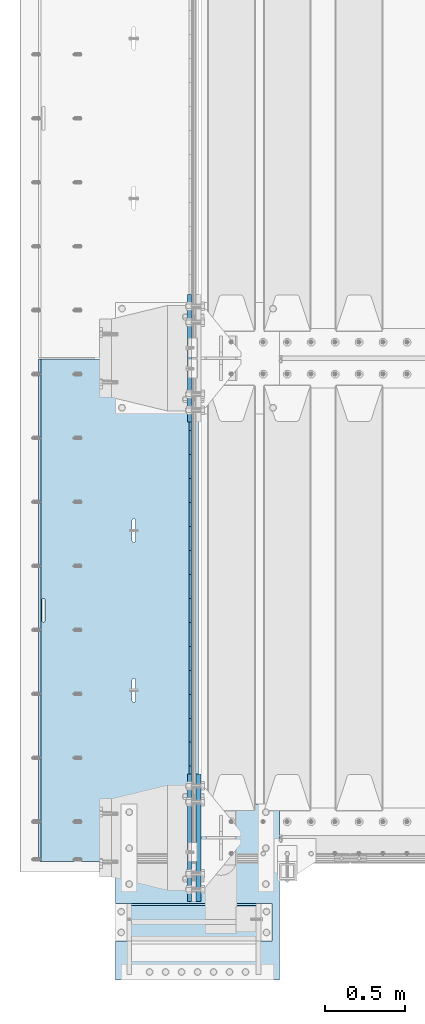
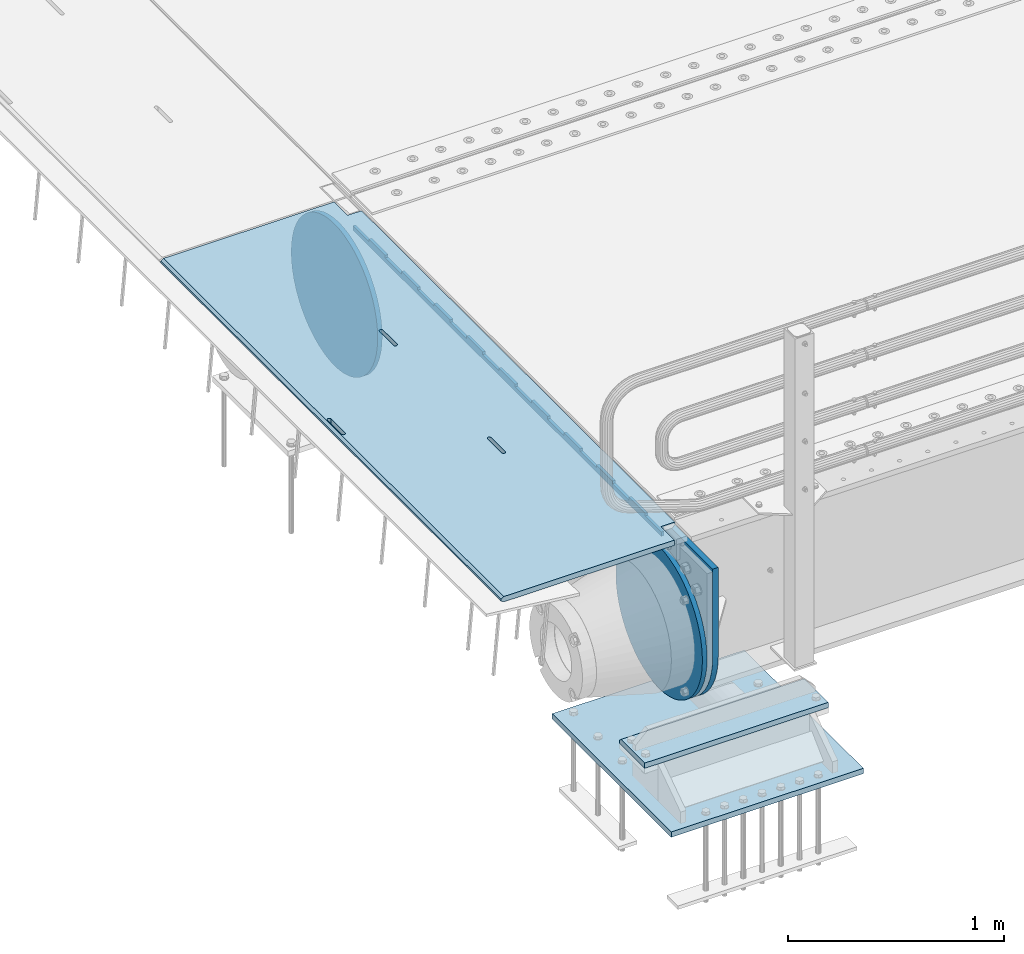
# One storey, part 168 of 219: 7 plates.
"""IFC2X3 building model written with IfcOpenShell, lengths in millimetres."""

from ifc_helpers import new_model, si_unit, frame, origin_with_axes, place, context, subcontext, project, spatial, faceted_brep, material, type_object, element, save


model = new_model("IFC2X3")

# Units and contexts
model_context = context("Model", 3, precision=1e-05, world=origin_with_axes())
body_context = subcontext(model_context, "Body", "Model", "MODEL_VIEW")
ifc_project = project(units=[si_unit("LENGTHUNIT", "METRE", prefix="MILLI"), si_unit("AREAUNIT", "SQUARE_METRE"), si_unit("VOLUMEUNIT", "CUBIC_METRE"), si_unit("MASSUNIT", "GRAM", prefix="KILO"), si_unit("TIMEUNIT", "SECOND"), si_unit("PLANEANGLEUNIT", "RADIAN"), si_unit("SOLIDANGLEUNIT", "STERADIAN"), si_unit("THERMODYNAMICTEMPERATUREUNIT", "DEGREE_CELSIUS"), si_unit("LUMINOUSINTENSITYUNIT", "LUMEN")], contexts=[model_context])

# Site, building, storey
site_placement = place(None, origin_with_axes())
site = spatial("IfcSite", under=ifc_project, at=site_placement, CompositionType="ELEMENT")
building_placement = place(site_placement, origin_with_axes())
building = spatial("IfcBuilding", under=site, at=building_placement, Name="Standard", CompositionType="ELEMENT")
storey_placement = place(building_placement, origin_with_axes())
storey = spatial("IfcBuildingStorey", under=building, at=storey_placement, Name="Undefined", CompositionType="ELEMENT", Elevation=0.0)

# Plates
ifc_material_1 = material(Name="STEEL/S355N")
plate_type_1 = type_object("IfcPlateType", PredefinedType="NOTDEFINED")
plate_1_placement = place(storey_placement, frame((-57.5000000000039, 26847.5000993725, -35.9858217365063), z_axis=(0.0, -0.999999999987744, -4.95099999993769e-06), x_axis=(0.0, 4.95100000930963e-06, -0.999999999987744)))
element("IfcPlate", 1, at=plate_1_placement, inside=storey, type_object=plate_type_1, material=ifc_material_1, context=body_context, shape_type="Brep", body=[
    faceted_brep([(0.0, -7.49999999999999, 0.0), (8.68993765834603e-12, -7.49999999999999, 150.000000000004), (8.68993765834603e-12, 7.5, 150.000000000004), (0.0, 7.5, 0.0), (-14.9999999999986, -7.49999999999999, 150.0), (-14.9999999999986, 7.5, 150.0), (-14.9999999999972, -7.49999999999999, 300.0), (-14.9999999999972, 7.5, 300.0), (1.55395696310734e-11, -7.49999999999999, 300.0), (1.55395696310734e-11, 7.5, 300.0), (1.87725390787818e-11, -7.49999999999999, 450.0), (1.87725390787818e-11, 7.5, 450.0), (-14.9999999999958, -7.49999999999999, 450.0), (-14.9999999999958, 7.5, 450.0), (-14.9999999999944, -7.49999999999999, 600.0), (-14.9999999999944, 7.5, 600.0), (2.74553713097703e-11, -7.49999999999999, 600.000000000004), (2.74553713097703e-11, 7.5, 600.000000000004), (3.24931193063094e-11, -7.49999999999999, 750.0), (3.24931193063094e-11, 7.5, 750.0), (-14.999999999993, -7.49999999999999, 750.0), (-14.999999999993, 7.5, 750.0), (-14.9999999999916, -7.49999999999999, 900.000000000004), (-14.9999999999916, 7.5, 900.000000000004), (4.11830569646554e-11, -7.49999999999999, 900.0), (4.11830569646554e-11, 7.5, 900.0), (4.62208049611945e-11, -7.49999999999999, 1050.0), (4.62208049611945e-11, 7.5, 1050.0), (-14.9999999999902, -7.49999999999999, 1050.0), (-14.9999999999902, 7.5, 1050.0), (-14.9999999999888, -7.49999999999999, 1200.0), (-14.9999999999888, 7.5, 1200.0), (5.30917532159947e-11, -7.49999999999999, 1200.0), (5.30917532159947e-11, 7.5, 1200.0), (5.99484906160797e-11, -7.49999999999999, 1350.0), (5.99484906160797e-11, 7.5, 1350.0), (-14.9999999999873, -7.49999999999999, 1350.0), (-14.9999999999873, 7.5, 1350.0), (-14.9999999999859, -7.49999999999999, 1500.0), (-14.9999999999859, 7.5, 1500.0), (6.49933440399764e-11, -7.49999999999999, 1500.0), (6.49933440399764e-11, 7.5, 1500.0), (7.36761762709648e-11, -7.49999999999999, 1650.0), (7.36761762709648e-11, 7.5, 1650.0), (-14.9999999999845, -7.49999999999999, 1650.0), (-14.9999999999845, 7.5, 1650.0), (-14.9999999999831, -7.49999999999999, 1800.0), (-14.9999999999831, 7.5, 1800.0), (7.6894934863958e-11, -7.49999999999999, 1800.0), (7.6894934863958e-11, 7.5, 1800.0), (8.37587776914006e-11, -7.49999999999999, 1950.0), (8.37587776914006e-11, 7.5, 1950.0), (-14.9999999999817, -7.49999999999999, 1950.0), (-14.9999999999817, 7.5, 1950.0), (-14.9999999999803, -7.49999999999999, 2100.0), (-14.9999999999803, 7.5, 2100.0), (9.06297259462008e-11, -7.49999999999999, 2100.0), (9.06297259462008e-11, 7.5, 2100.0), (9.56674739427399e-11, -7.49999999999999, 2250.0), (9.56674739427399e-11, 7.5, 2250.0), (-14.9999999999789, -7.49999999999999, 2250.0), (-14.9999999999789, 7.5, 2250.0), (-14.9999999999775, -7.49999999999999, 2400.0), (-14.9999999999775, 7.5, 2400.0), (1.04350306173728e-10, -7.49999999999999, 2400.0), (1.04350306173728e-10, 7.5, 2400.0), (1.09388054170267e-10, -7.49999999999999, 2550.0), (1.09388054170267e-10, 7.5, 2550.0), (-14.9999999999761, -7.49999999999999, 2550.0), (-14.9999999999761, 7.5, 2550.0), (-14.9999999999747, -7.49999999999999, 2700.0), (-14.9999999999747, 7.5, 2700.0), (1.14440013021522e-10, -7.49999999999999, 2700.0), (1.14440013021522e-10, 7.5, 2700.0), (1.23115739825153e-10, -7.49999999999999, 2850.0), (1.23115739825153e-10, 7.5, 2850.0), (25.0000000000267, -7.49999999999999, 2850.0), (25.0000000000267, 7.5, 2850.0), (25.0, -7.49999999999999, 0.0), (25.0, 7.5, 0.0)], [[[0, 1, 2, 3]], [[1, 4, 5, 2]], [[4, 6, 7, 5]], [[6, 8, 9, 7]], [[8, 10, 11, 9]], [[10, 12, 13, 11]], [[12, 14, 15, 13]], [[14, 16, 17, 15]], [[16, 18, 19, 17]], [[18, 20, 21, 19]], [[20, 22, 23, 21]], [[22, 24, 25, 23]], [[24, 26, 27, 25]], [[26, 28, 29, 27]], [[28, 30, 31, 29]], [[30, 32, 33, 31]], [[32, 34, 35, 33]], [[34, 36, 37, 35]], [[36, 38, 39, 37]], [[38, 40, 41, 39]], [[40, 42, 43, 41]], [[42, 44, 45, 43]], [[44, 46, 47, 45]], [[46, 48, 49, 47]], [[48, 50, 51, 49]], [[50, 52, 53, 51]], [[52, 54, 55, 53]], [[54, 56, 57, 55]], [[56, 58, 59, 57]], [[58, 60, 61, 59]], [[60, 62, 63, 61]], [[62, 64, 65, 63]], [[64, 66, 67, 65]], [[66, 68, 69, 67]], [[68, 70, 71, 69]], [[70, 72, 73, 71]], [[72, 74, 75, 73]], [[74, 76, 77, 75]], [[76, 78, 79, 77]], [[78, 0, 3, 79]], [[5, 7, 9, 11, 13, 15, 17, 19, 21, 23, 25, 27, 29, 31, 33, 35, 37, 39, 41, 43, 45, 47, 49, 51, 53, 55, 57, 59, 61, 63, 65, 67, 69, 71, 73, 75, 77, 79, 3, 2]], [[78, 76, 74, 72, 70, 68, 66, 64, 62, 60, 58, 56, 54, 52, 50, 48, 46, 44, 42, 40, 38, 36, 34, 32, 30, 28, 26, 24, 22, 20, 18, 16, 14, 12, 10, 8, 6, 4, 1, 0]]]),
])
plate_type_2 = type_object("IfcPlateType", PredefinedType="NOTDEFINED")
plate_2_placement = place(storey_placement, frame((-5.00375457095084, 26994.9999261293, -0.984429074950506), z_axis=(0.0, -0.999999999987744, -4.95099999993769e-06), x_axis=(-0.999999999879068, -1.00000022172504e-09, -1.55519999981193e-05)))
element("IfcPlate", 2, at=plate_2_placement, inside=storey, type_object=plate_type_2, material=ifc_material_1, context=body_context, shape_type="Brep", body=[
    faceted_brep([(14.9998601691701, 15.0, 125.000024820867), (-0.000294611402126499, -0.000806902977099622, 124.999936248674), (-0.0019194158154896, 0.000806844435372156, 3020.00000492308), (14.9966216875132, 15.0, 3020.00007976656), (999.996459960937, 4.99999999999999, 3.63797880709171e-12), (984.996459960937, 15.0, 3.63797880709171e-12), (984.996459718778, 15.0, 3145.0), (999.996459718778, 4.99999999999999, 3145.0), (984.996459961366, -15.0, 0.0), (999.996459960937, -5.0, 3.63797880709171e-12), (999.996459718778, -5.0, 3145.0), (984.996459719206, -15.0, 3145.0), (74.999782061445, -15.0, 0.0), (74.9996421865538, -15.0000000127077, 124.999930084141), (75.0001087165527, 15.0, 125.00007975414), (75.0002485914438, 15.0, 0.0), (-0.000449375328763324, -14.9999999951864, 124.999861417786), (960.486056642603, -14.9999999941054, 1504.40983005424), (960.486056642603, 15.0, 1504.40983005424), (959.996621805317, 15.0, 1507.49999999799), (959.996621805317, -14.9999999941178, 1507.49999999799), (961.90645186202, -14.9999999940729, 1501.62214747507), (961.906451862021, 15.0, 1501.62214747506), (964.118769283016, -14.9999999940233, 1499.40983005424), (964.118769283016, 15.0, 1499.40983005424), (966.9064518623, -14.9999999939616, 1497.98943483504), (966.906451862301, 15.0, 1497.98943483504), (969.996621806087, -14.9999999938938, 1497.49999999799), (969.996621806088, 15.0, 1497.49999999799), (973.086791749683, -14.9999999938266, 1497.98943483504), (973.086791749683, 15.0, 1497.98943483504), (975.874474328748, -14.9999999937664, 1499.40983005424), (975.874474328748, 15.0, 1499.40983005424), (978.086791749402, -14.9999999937193, 1501.62214747506), (978.086791749402, 15.0, 1501.62214747506), (979.50718696839, -14.9999999936897, 1504.40983005424), (979.50718696839, 15.0, 1504.40983005424), (979.996621805202, -14.9999999936807, 1507.49999999798), (979.996621805202, 15.0, 1507.49999999798), (979.996621795288, -14.9999999937513, 1637.49999999798), (979.996621795288, 15.0, 1637.49999999798), (979.507186958004, -14.9999999937636, 1640.59016994173), (979.507186958004, 15.0, 1640.59016994173), (978.086791738588, -14.9999999937962, 1643.37785252092), (978.086791738588, 15.0, 1643.37785252092), (975.874474317592, -14.9999999938457, 1645.59016994174), (975.874474317592, 15.0, 1645.59016994174), (973.086791738306, -14.9999999939074, 1647.01056516094), (973.086791738306, 15.0, 1647.01056516094), (969.996621794518, -14.9999999939752, 1647.499999998), (969.996621794518, 15.0, 1647.49999999799), (966.906451850814, -14.9999999940425, 1647.01056516094), (966.906451850814, 15.0, 1647.01056516094), (964.118769271748, -14.9999999941026, 1645.59016994174), (964.118769271748, 15.0, 1645.59016994174), (961.906451851094, -14.9999999941498, 1643.37785252092), (961.906451851094, 15.0, 1643.37785252092), (960.486056632107, -14.9999999941793, 1640.59016994174), (960.486056632107, 15.0, 1640.59016994174), (959.996621795297, -14.9999999941883, 1637.49999999799), (959.996621795297, 15.0, 1637.49999999799), (395.486056681091, -15.0000000061812, 1004.40983005449), (395.486056681091, 15.0, 1004.40983005448), (394.996621843805, 15.0, 1007.49999999824), (394.996621843805, -15.0000000061936, 1007.49999999824), (396.906451900508, -15.0000000061487, 1001.62214747531), (396.906451900508, 15.0, 1001.62214747531), (399.118769321504, -15.0000000060991, 999.409830054483), (399.118769321504, 15.0, 999.409830054483), (401.906451900788, -15.0000000060374, 997.989434835286), (401.906451900788, 15.0, 997.989434835283), (404.996621844575, -15.0000000059696, 997.499999998232), (404.996621844575, 15.0, 997.499999998228), (408.086791788171, -15.0000000059024, 997.989434835283), (408.086791788171, 15.0, 997.989434835283), (410.874474367236, -15.0000000058422, 999.409830054483), (410.874474367236, 15.0, 999.409830054483), (413.08679178789, -15.0000000057951, 1001.62214747531), (413.08679178789, 15.0, 1001.6221474753), (414.507187006878, -15.0000000057655, 1004.40983005448), (414.507187006878, 15.0, 1004.40983005448), (414.99662184369, -15.0000000057565, 1007.49999999823), (414.99662184369, 15.0, 1007.49999999822), (414.996621833776, -15.0000000058271, 1137.49999999823), (414.996621833776, 15.0, 1137.49999999822), (414.507186996492, -15.0000000058395, 1140.59016994198), (414.507186996492, 15.0, 1140.59016994198), (413.086791777076, -15.000000005872, 1143.37785252116), (413.086791777076, 15.0, 1143.37785252115), (410.87447435608, -15.0000000059215, 1145.59016994198), (410.87447435608, 15.0, 1145.59016994198), (408.086791776794, -15.0000000059832, 1147.01056516119), (408.086791776794, 15.0, 1147.01056516119), (404.996621833006, -15.000000006051, 1147.49999999823), (404.996621833006, 15.0, 1147.49999999823), (401.906451889302, -15.0000000061183, 1147.01056516119), (401.906451889302, 15.0, 1147.01056516118), (399.118769310236, -15.0000000061784, 1145.59016994198), (399.118769310236, 15.0, 1145.59016994198), (396.906451889582, -15.0000000062256, 1143.37785252116), (396.906451889582, 15.0, 1143.37785252116), (395.486056670595, -15.0000000062551, 1140.59016994198), (395.486056670595, 15.0, 1140.59016994198), (394.996621833785, -15.0000000062641, 1137.49999999824), (394.996621833785, 15.0, 1137.49999999824), (74.9967306508983, 15.0, 3145.0), (74.9962640908995, -15.0, 3145.0), (74.9968705257886, 15.0, 3020.00007982416), (74.9964039657899, -15.0, 3019.99993015416), (-0.000460362174934836, -15.00000004538, 3019.99993008595), (395.486056593611, -15.0000000067978, 2140.5901699415), (396.906451812598, -15.0000000067683, 2143.37785252068), (399.118769233252, -15.0000000067211, 2145.5901699415), (401.906451812318, -15.000000006661, 2147.01056516071), (404.996621756022, -15.0000000065937, 2147.49999999775), (408.08679169981, -15.0000000065259, 2147.01056516071), (410.874474279096, -15.0000000064642, 2145.5901699415), (413.086791700092, -15.0000000064147, 2143.37785252068), (414.507186919508, -15.0000000063821, 2140.5901699415), (414.996621756792, -15.0000000063698, 2137.49999999775), (414.996621766706, -15.0000000062992, 2007.49999999775), (414.507186929894, -15.0000000063082, 2004.409830054), (413.086791710906, -15.0000000063378, 2001.62214747483), (410.874474290252, -15.0000000063849, 1999.409830054), (408.086791711187, -15.0000000064451, 1997.9894348348), (404.996621767592, -15.0000000065123, 1997.49999999776), (401.906451823804, -15.0000000065801, 1997.98943483481), (399.11876924452, -15.0000000066418, 1999.409830054), (396.906451823524, -15.0000000066914, 2001.62214747483), (395.486056604107, -15.0000000067239, 2004.409830054), (394.996621766821, -15.0000000067363, 2007.49999999776), (394.996621756801, -15.0000000068068, 2137.49999999776), (396.906451823524, 15.0, 2001.62214747483), (395.486056604107, 15.0, 2004.409830054), (399.11876924452, 15.0, 1999.409830054), (401.906451823804, 15.0, 1997.9894348348), (404.996621767592, 15.0, 1997.49999999775), (408.086791711187, 15.0, 1997.9894348348), (410.874474290252, 15.0, 1999.409830054), (413.086791710906, 15.0, 2001.62214747482), (414.507186929894, 15.0, 2004.409830054), (414.996621766706, 15.0, 2007.49999999774), (414.996621756792, 15.0, 2137.49999999774), (414.507186919508, 15.0, 2140.5901699415), (413.086791700092, 15.0, 2143.37785252067), (410.874474279096, 15.0, 2145.5901699415), (408.08679169981, 15.0, 2147.01056516071), (404.996621756022, 15.0, 2147.49999999775), (401.906451812318, 15.0, 2147.0105651607), (399.118769233252, 15.0, 2145.5901699415), (396.906451812598, 15.0, 2143.37785252068), (395.486056593611, 15.0, 2140.5901699415), (394.996621756801, 15.0, 2137.49999999776), (394.996621766821, 15.0, 2007.49999999776)], [[[0, 1, 2, 3]], [[4, 5, 6, 7]], [[8, 9, 10, 11]], [[12, 13, 14, 15]], [[14, 13, 16, 1, 0]], [[17, 18, 19, 20]], [[21, 22, 18, 17]], [[23, 24, 22, 21]], [[25, 26, 24, 23]], [[27, 28, 26, 25]], [[29, 30, 28, 27]], [[31, 32, 30, 29]], [[33, 34, 32, 31]], [[35, 36, 34, 33]], [[37, 38, 36, 35]], [[39, 40, 38, 37]], [[41, 42, 40, 39]], [[43, 44, 42, 41]], [[45, 46, 44, 43]], [[47, 48, 46, 45]], [[49, 50, 48, 47]], [[51, 52, 50, 49]], [[53, 54, 52, 51]], [[55, 56, 54, 53]], [[57, 58, 56, 55]], [[59, 60, 58, 57]], [[20, 19, 60, 59]], [[61, 62, 63, 64]], [[65, 66, 62, 61]], [[67, 68, 66, 65]], [[69, 70, 68, 67]], [[71, 72, 70, 69]], [[73, 74, 72, 71]], [[75, 76, 74, 73]], [[77, 78, 76, 75]], [[79, 80, 78, 77]], [[81, 82, 80, 79]], [[83, 84, 82, 81]], [[85, 86, 84, 83]], [[87, 88, 86, 85]], [[89, 90, 88, 87]], [[91, 92, 90, 89]], [[93, 94, 92, 91]], [[95, 96, 94, 93]], [[97, 98, 96, 95]], [[99, 100, 98, 97]], [[101, 102, 100, 99]], [[103, 104, 102, 101]], [[64, 63, 104, 103]], [[9, 8, 12, 15, 5, 4]], [[10, 9, 4, 7]], [[105, 106, 11, 10, 7, 6]], [[106, 105, 107, 108]], [[109, 108, 107, 3, 2]], [[106, 108, 109, 16, 13, 12, 8, 11], [101, 99, 97, 95, 93, 91, 89, 87, 85, 83, 81, 79, 77, 75, 73, 71, 69, 67, 65, 61, 64, 103], [57, 55, 53, 51, 49, 47, 45, 43, 41, 39, 37, 35, 33, 31, 29, 27, 25, 23, 21, 17, 20, 59], [110, 111, 112, 113, 114, 115, 116, 117, 118, 119, 120, 121, 122, 123, 124, 125, 126, 127, 128, 129, 130, 131]], [[128, 132, 133, 129]], [[127, 134, 132, 128]], [[126, 135, 134, 127]], [[125, 136, 135, 126]], [[124, 137, 136, 125]], [[123, 138, 137, 124]], [[122, 139, 138, 123]], [[121, 140, 139, 122]], [[120, 141, 140, 121]], [[119, 142, 141, 120]], [[118, 143, 142, 119]], [[117, 144, 143, 118]], [[116, 145, 144, 117]], [[115, 146, 145, 116]], [[114, 147, 146, 115]], [[113, 148, 147, 114]], [[112, 149, 148, 113]], [[111, 150, 149, 112]], [[110, 151, 150, 111]], [[131, 152, 151, 110]], [[130, 153, 152, 131]], [[129, 133, 153, 130]], [[107, 105, 6, 5, 15, 14, 0, 3], [132, 134, 135, 136, 137, 138, 139, 140, 141, 142, 143, 144, 145, 146, 147, 148, 149, 150, 151, 152, 153, 133], [22, 24, 26, 28, 30, 32, 34, 36, 38, 40, 42, 44, 46, 48, 50, 52, 54, 56, 58, 60, 19, 18], [66, 68, 70, 72, 74, 76, 78, 80, 82, 84, 86, 88, 90, 92, 94, 96, 98, 100, 102, 104, 63, 62]], [[16, 109, 2, 1]]]),
])
ifc_material_2 = material()
plate_type_3 = type_object("IfcPlateType", PredefinedType="NOTDEFINED")
plate_3_placement = place(storey_placement, frame((455.000000000013, 23355.0, -803.000000000004), z_axis=(0.0, 1.0, 0.0), x_axis=(-1.0, 0.0, 0.0)))
element("IfcPlate", 3, at=plate_3_placement, inside=storey, type_object=plate_type_3, material=ifc_material_2, context=body_context, shape_type="Brep", body=[
    faceted_brep([(979.0, 0.0, 235.0), (979.0, 15.0, 220.0), (0.0, 15.0, 220.0), (0.0, 0.0, 235.0), (0.0, 15.0, 0.0), (0.0, -15.0, 0.0), (0.0, -15.0, 235.0), (979.0, -15.0, 235.0), (979.0, -15.0, 0.0), (979.0, 15.0, 0.0)], [[[0, 1, 2, 3]], [[4, 5, 6, 3, 2]], [[6, 7, 0, 3]], [[7, 8, 9, 1, 0]], [[8, 5, 4, 9]], [[9, 4, 2, 1]], [[8, 7, 6, 5]]]),
])
plate_type_4 = type_object("IfcPlateType", PredefinedType="NOTDEFINED")
plate_4_placement = place(storey_placement, frame((-523.999999999987, 23110.0, -1043.0), z_axis=(1.0, 0.0, 0.0), x_axis=(0.0, 1.0, 0.0)))
element("IfcPlate", 4, at=plate_4_placement, inside=storey, type_object=plate_type_4, material=ifc_material_2, context=body_context, shape_type="Brep", body=[
    faceted_brep([(0.0, -15.0, 0.0), (3.03448287013453e-05, -15.0, 1025.0), (3.03448287013453e-05, 15.0, 1025.0), (0.0, 15.0, 0.0), (1100.0, -15.0, 1025.0), (1100.0, 15.0, 1025.0), (1100.0, -15.0, -1.9554136088118e-11), (1100.0, 15.0, -1.9554136088118e-11)], [[[0, 1, 2, 3]], [[1, 4, 5, 2]], [[4, 6, 7, 5]], [[6, 0, 3, 7]], [[5, 7, 3, 2]], [[6, 4, 1, 0]]]),
])
plate_type_5 = type_object("IfcPlateType", PredefinedType="NOTDEFINED")
plate_5_placement = place(storey_placement, frame((-62.5000000000001, 27400.0, -114.999999999998), z_axis=(0.0, 0.0, -1.0), x_axis=(0.0, -1.0, 0.0)))
element("IfcPlate", 5, at=plate_5_placement, inside=storey, type_object=plate_type_5, material=ifc_material_1, context=body_context, shape_type="Brep", body=[
    faceted_brep([(0.0, -12.5, 400.0), (2.91645036198315, -12.5, 448.214672101512), (2.91645036198315, 12.5, 448.214672101512), (0.0, 12.5, 400.0), (11.6232730309421, -12.5, 495.72626571426), (11.6232730309421, 12.5, 495.72626571426), (25.9935029273329, -12.5, 541.8419548161), (25.9935029273329, 12.5, 541.8419548161), (45.8175897403271, -12.5, 585.889268816449), (45.8175897403271, 12.5, 585.889268816449), (70.8064536442325, -12.5, 627.225898691271), (70.8064536442325, 12.5, 627.225898691271), (100.595700733313, -12.5, 665.249063294999), (100.595700733313, 12.5, 665.249063294999), (134.750936705474, -12.5, 699.404299267018), (134.750936705474, 12.5, 699.404299267018), (172.774101309333, -12.5, 729.193546355957), (172.774101309333, 12.5, 729.193546355957), (214.110731184279, -12.5, 754.182410259709), (214.110731184279, 12.5, 754.182410259709), (258.15804518474, -12.5, 774.006497072558), (258.15804518474, 12.5, 774.006497072558), (304.273734286682, -12.5, 788.376726968803), (304.273734286682, 12.5, 788.376726968803), (351.785327899517, -12.5, 797.08354963762), (351.785327899517, 12.5, 797.08354963762), (400.0, -12.5, 800.0), (400.0, 12.5, 800.0), (448.21467210335, -12.5, 797.083549637642), (448.21467210335, 12.5, 797.083549637642), (495.726265715995, -12.5, 788.37672696916), (495.726265715995, 12.5, 788.37672696916), (541.841954817748, -12.5, 774.006497073235), (541.841954817748, 12.5, 774.006497073235), (585.889268818006, -12.5, 754.182410260695), (585.889268818006, 12.5, 754.182410260695), (627.225898692734, -12.5, 729.193546357212), (627.225898692734, 12.5, 729.193546357212), (665.249063296356, -12.5, 699.404299268539), (665.249063296356, 12.5, 699.404299268539), (699.404299268259, -12.5, 665.24906329676), (699.404299268259, 12.5, 665.24906329676), (729.193546357063, -12.5, 627.22589869325), (729.193546357063, 12.5, 627.22589869325), (754.18241026067, -12.5, 585.889268818639), (754.18241026067, 12.5, 585.889268818639), (774.006497073347, -12.5, 541.841954818479), (774.006497073347, 12.5, 541.841954818479), (788.376726969396, -12.5, 495.726265716821), (788.376726969396, 12.5, 495.726265716821), (797.083549638002, -12.5, 448.214672104252), (797.083549638002, 12.5, 448.214672104252), (800.0, -12.5, 400.0), (800.0, 12.5, 400.0), (797.083549639287, -12.5, 351.785327898364), (797.083549639287, 12.5, 351.785327898364), (788.376726970528, -12.5, 304.273734285453), (788.376726970528, 12.5, 304.273734285453), (774.006497074311, -12.5, 258.158045183416), (774.006497074311, 12.5, 258.158045183416), (754.182410261463, -12.5, 214.110731182853), (754.182410261463, 12.5, 214.110731182853), (729.193546357659, -12.5, 172.774101307812), (729.193546357659, 12.5, 172.774101307812), (699.404299268663, -12.5, 134.750936703855), (699.404299268663, 12.5, 134.750936703855), (665.24906329656, -12.5, 100.595700731628), (665.24906329656, 12.5, 100.595700731628), (627.225898692719, -12.5, 70.8064536425045), (627.225898692719, 12.5, 70.8064536425045), (585.889268817788, -12.5, 45.8175897385809), (585.889268817788, 12.5, 45.8175897385809), (541.841954817326, -12.5, 25.9935029256012), (541.841954817326, 12.5, 25.9935029256012), (495.726265715377, -12.5, 11.6232730292504), (495.726265715377, 12.5, 11.6232730292504), (448.214672102542, -12.5, 2.91645036037517), (448.214672102542, 12.5, 2.91645036037517), (400.0, -12.5, -5.6843418860808e-14), (400.0, 12.5, -5.6843418860808e-14), (351.785327896665, -12.5, 2.91645036236514), (351.785327896665, 12.5, 2.91645036236514), (304.273734284012, -12.5, 11.6232730308511), (304.273734284012, 12.5, 11.6232730308511), (258.158045182267, -12.5, 25.9935029267763), (258.158045182267, 12.5, 25.9935029267763), (214.110731182009, -12.5, 45.8175897393157), (214.110731182009, 12.5, 45.8175897393157), (172.774101307281, -12.5, 70.8064536427992), (172.774101307281, 12.5, 70.8064536427992), (134.750936703655, -12.5, 100.595700731472), (134.750936703655, 12.5, 100.595700731472), (100.595700731748, -12.5, 134.750936703247), (100.595700731748, 12.5, 134.750936703247), (70.8064536429447, -12.5, 172.774101306761), (70.8064536429447, 12.5, 172.774101306761), (45.8175897393376, -12.5, 214.110731181379), (45.8175897393376, 12.5, 214.110731181379), (25.9935029266635, -12.5, 258.158045181532), (25.9935029266635, 12.5, 258.158045181532), (11.6232730306074, -12.5, 304.273734283186), (11.6232730306074, 12.5, 304.273734283186), (2.9164503619977, -12.5, 351.785327895759), (2.9164503619977, 12.5, 351.785327895759)], [[[0, 1, 2, 3]], [[1, 4, 5, 2]], [[4, 6, 7, 5]], [[6, 8, 9, 7]], [[8, 10, 11, 9]], [[10, 12, 13, 11]], [[12, 14, 15, 13]], [[14, 16, 17, 15]], [[16, 18, 19, 17]], [[18, 20, 21, 19]], [[20, 22, 23, 21]], [[22, 24, 25, 23]], [[24, 26, 27, 25]], [[26, 28, 29, 27]], [[28, 30, 31, 29]], [[30, 32, 33, 31]], [[32, 34, 35, 33]], [[34, 36, 37, 35]], [[36, 38, 39, 37]], [[38, 40, 41, 39]], [[40, 42, 43, 41]], [[42, 44, 45, 43]], [[44, 46, 47, 45]], [[46, 48, 49, 47]], [[48, 50, 51, 49]], [[50, 52, 53, 51]], [[52, 54, 55, 53]], [[54, 56, 57, 55]], [[56, 58, 59, 57]], [[58, 60, 61, 59]], [[60, 62, 63, 61]], [[62, 64, 65, 63]], [[64, 66, 67, 65]], [[66, 68, 69, 67]], [[68, 70, 71, 69]], [[70, 72, 73, 71]], [[72, 74, 75, 73]], [[74, 76, 77, 75]], [[76, 78, 79, 77]], [[78, 80, 81, 79]], [[80, 82, 83, 81]], [[82, 84, 85, 83]], [[84, 86, 87, 85]], [[86, 88, 89, 87]], [[88, 90, 91, 89]], [[90, 92, 93, 91]], [[92, 94, 95, 93]], [[94, 96, 97, 95]], [[96, 98, 99, 97]], [[98, 100, 101, 99]], [[100, 102, 103, 101]], [[102, 0, 3, 103]], [[5, 7, 9, 11, 13, 15, 17, 19, 21, 23, 25, 27, 29, 31, 33, 35, 37, 39, 41, 43, 45, 47, 49, 51, 53, 55, 57, 59, 61, 63, 65, 67, 69, 71, 73, 75, 77, 79, 81, 83, 85, 87, 89, 91, 93, 95, 97, 99, 101, 103, 3, 2]], [[102, 100, 98, 96, 94, 92, 90, 88, 86, 84, 82, 80, 78, 76, 74, 72, 70, 68, 66, 64, 62, 60, 58, 56, 54, 52, 50, 48, 46, 44, 42, 40, 38, 36, 34, 32, 30, 28, 26, 24, 22, 20, 18, 16, 14, 12, 10, 8, 6, 4, 1, 0]]]),
])
plate_6_placement = place(storey_placement, frame((-62.5000000000001, 24400.0, -114.999999999998), z_axis=(0.0, 0.0, -1.0), x_axis=(0.0, -1.0, 0.0)))
element("IfcPlate", 6, at=plate_6_placement, inside=storey, type_object=plate_type_5, material=ifc_material_1, context=body_context, shape_type="Brep", body=[
    faceted_brep([(0.0, -12.5, 400.0), (2.91645036198315, -12.5, 448.214672101512), (2.91645036198315, 12.5, 448.214672101512), (0.0, 12.5, 400.0), (11.6232730309421, -12.5, 495.72626571426), (11.6232730309421, 12.5, 495.72626571426), (25.9935029273329, -12.5, 541.8419548161), (25.9935029273329, 12.5, 541.8419548161), (45.8175897403271, -12.5, 585.889268816449), (45.8175897403271, 12.5, 585.889268816449), (70.8064536442325, -12.5, 627.225898691271), (70.8064536442325, 12.5, 627.225898691271), (100.595700733313, -12.5, 665.249063294999), (100.595700733313, 12.5, 665.249063294999), (134.750936705474, -12.5, 699.404299267018), (134.750936705474, 12.5, 699.404299267018), (172.774101309333, -12.5, 729.193546355957), (172.774101309333, 12.5, 729.193546355957), (214.110731184279, -12.5, 754.182410259709), (214.110731184279, 12.5, 754.182410259709), (258.15804518474, -12.5, 774.006497072558), (258.15804518474, 12.5, 774.006497072558), (304.273734286682, -12.5, 788.376726968803), (304.273734286682, 12.5, 788.376726968803), (351.785327899517, -12.5, 797.08354963762), (351.785327899517, 12.5, 797.08354963762), (400.0, -12.5, 800.0), (400.0, 12.5, 800.0), (448.21467210335, -12.5, 797.083549637642), (448.21467210335, 12.5, 797.083549637642), (495.726265715995, -12.5, 788.37672696916), (495.726265715995, 12.5, 788.37672696916), (541.841954817748, -12.5, 774.006497073235), (541.841954817748, 12.5, 774.006497073235), (585.889268818006, -12.5, 754.182410260695), (585.889268818006, 12.5, 754.182410260695), (627.225898692734, -12.5, 729.193546357212), (627.225898692734, 12.5, 729.193546357212), (665.249063296356, -12.5, 699.404299268539), (665.249063296356, 12.5, 699.404299268539), (699.404299268259, -12.5, 665.24906329676), (699.404299268259, 12.5, 665.24906329676), (729.193546357063, -12.5, 627.22589869325), (729.193546357063, 12.5, 627.22589869325), (754.18241026067, -12.5, 585.889268818639), (754.18241026067, 12.5, 585.889268818639), (774.006497073347, -12.5, 541.841954818479), (774.006497073347, 12.5, 541.841954818479), (788.376726969396, -12.5, 495.726265716821), (788.376726969396, 12.5, 495.726265716821), (797.083549638002, -12.5, 448.214672104252), (797.083549638002, 12.5, 448.214672104252), (800.0, -12.5, 400.0), (800.0, 12.5, 400.0), (797.083549639287, -12.5, 351.785327898364), (797.083549639287, 12.5, 351.785327898364), (788.376726970528, -12.5, 304.273734285453), (788.376726970528, 12.5, 304.273734285453), (774.006497074311, -12.5, 258.158045183416), (774.006497074311, 12.5, 258.158045183416), (754.182410261463, -12.5, 214.110731182853), (754.182410261463, 12.5, 214.110731182853), (729.193546357659, -12.5, 172.774101307812), (729.193546357659, 12.5, 172.774101307812), (699.404299268663, -12.5, 134.750936703855), (699.404299268663, 12.5, 134.750936703855), (665.24906329656, -12.5, 100.595700731628), (665.24906329656, 12.5, 100.595700731628), (627.225898692719, -12.5, 70.8064536425045), (627.225898692719, 12.5, 70.8064536425045), (585.889268817788, -12.5, 45.8175897385809), (585.889268817788, 12.5, 45.8175897385809), (541.841954817326, -12.5, 25.9935029256012), (541.841954817326, 12.5, 25.9935029256012), (495.726265715377, -12.5, 11.6232730292504), (495.726265715377, 12.5, 11.6232730292504), (448.214672102542, -12.5, 2.91645036037517), (448.214672102542, 12.5, 2.91645036037517), (400.0, -12.5, -5.6843418860808e-14), (400.0, 12.5, -5.6843418860808e-14), (351.785327896665, -12.5, 2.91645036236514), (351.785327896665, 12.5, 2.91645036236514), (304.273734284012, -12.5, 11.6232730308511), (304.273734284012, 12.5, 11.6232730308511), (258.158045182267, -12.5, 25.9935029267763), (258.158045182267, 12.5, 25.9935029267763), (214.110731182009, -12.5, 45.8175897393157), (214.110731182009, 12.5, 45.8175897393157), (172.774101307281, -12.5, 70.8064536427992), (172.774101307281, 12.5, 70.8064536427992), (134.750936703655, -12.5, 100.595700731472), (134.750936703655, 12.5, 100.595700731472), (100.595700731748, -12.5, 134.750936703247), (100.595700731748, 12.5, 134.750936703247), (70.8064536429447, -12.5, 172.774101306761), (70.8064536429447, 12.5, 172.774101306761), (45.8175897393376, -12.5, 214.110731181379), (45.8175897393376, 12.5, 214.110731181379), (25.9935029266635, -12.5, 258.158045181532), (25.9935029266635, 12.5, 258.158045181532), (11.6232730306074, -12.5, 304.273734283186), (11.6232730306074, 12.5, 304.273734283186), (2.9164503619977, -12.5, 351.785327895759), (2.9164503619977, 12.5, 351.785327895759)], [[[0, 1, 2, 3]], [[1, 4, 5, 2]], [[4, 6, 7, 5]], [[6, 8, 9, 7]], [[8, 10, 11, 9]], [[10, 12, 13, 11]], [[12, 14, 15, 13]], [[14, 16, 17, 15]], [[16, 18, 19, 17]], [[18, 20, 21, 19]], [[20, 22, 23, 21]], [[22, 24, 25, 23]], [[24, 26, 27, 25]], [[26, 28, 29, 27]], [[28, 30, 31, 29]], [[30, 32, 33, 31]], [[32, 34, 35, 33]], [[34, 36, 37, 35]], [[36, 38, 39, 37]], [[38, 40, 41, 39]], [[40, 42, 43, 41]], [[42, 44, 45, 43]], [[44, 46, 47, 45]], [[46, 48, 49, 47]], [[48, 50, 51, 49]], [[50, 52, 53, 51]], [[52, 54, 55, 53]], [[54, 56, 57, 55]], [[56, 58, 59, 57]], [[58, 60, 61, 59]], [[60, 62, 63, 61]], [[62, 64, 65, 63]], [[64, 66, 67, 65]], [[66, 68, 69, 67]], [[68, 70, 71, 69]], [[70, 72, 73, 71]], [[72, 74, 75, 73]], [[74, 76, 77, 75]], [[76, 78, 79, 77]], [[78, 80, 81, 79]], [[80, 82, 83, 81]], [[82, 84, 85, 83]], [[84, 86, 87, 85]], [[86, 88, 89, 87]], [[88, 90, 91, 89]], [[90, 92, 93, 91]], [[92, 94, 95, 93]], [[94, 96, 97, 95]], [[96, 98, 99, 97]], [[98, 100, 101, 99]], [[100, 102, 103, 101]], [[102, 0, 3, 103]], [[5, 7, 9, 11, 13, 15, 17, 19, 21, 23, 25, 27, 29, 31, 33, 35, 37, 39, 41, 43, 45, 47, 49, 51, 53, 55, 57, 59, 61, 63, 65, 67, 69, 71, 73, 75, 77, 79, 81, 83, 85, 87, 89, 91, 93, 95, 97, 99, 101, 103, 3, 2]], [[102, 100, 98, 96, 94, 92, 90, 88, 86, 84, 82, 80, 78, 76, 74, 72, 70, 68, 66, 64, 62, 60, 58, 56, 54, 52, 50, 48, 46, 44, 42, 40, 38, 36, 34, 32, 30, 28, 26, 24, 22, 20, 18, 16, 14, 12, 10, 8, 6, 4, 1, 0]]]),
])
plate_type_6 = type_object("IfcPlateType", PredefinedType="NOTDEFINED")
plate_7_placement = place(storey_placement, frame((-5.0, 23600.0, -20.0), z_axis=(0.0, 1.0, 0.0), x_axis=(0.0, 0.0, -1.0)))
element("IfcPlate", 7, at=plate_7_placement, inside=storey, type_object=plate_type_6, material=ifc_material_1, context=body_context, shape_type="Brep", body=[
    faceted_brep([(855.0, -15.0, 572.963114670027), (855.0, 15.0, 572.963114670027), (849.182410260917, 15.0, 585.889268816907), (849.182410260917, -15.0, 585.889268816907), (824.193546357179, 15.0, 627.225898691897), (824.193546357179, -15.0, 627.225898691897), (794.404299268237, 15.0, 665.249063295792), (794.404299268237, -15.0, 665.249063295792), (760.249063296204, 15.0, 699.404299267975), (760.249063296204, -15.0, 699.404299267975), (722.225898692443, 15.0, 729.193546357055), (722.225898692443, -15.0, 729.193546357055), (680.889268817573, 15.0, 754.182410260939), (680.889268817573, -15.0, 754.182410260939), (636.841954817181, 15.0, 774.006497073904), (636.841954817181, -15.0, 774.006497073904), (590.726265715286, 15.0, 788.376726970237), (590.726265715286, -15.0, 788.376726970237), (543.214672102495, 15.0, 797.083549639108), (543.214672102495, -15.0, 797.083549639108), (495.0, -15.0, 800.000000000029), (495.0, 15.0, 800.0), (494.999999999412, -15.0, 0.0), (494.999999999412, 15.0, 0.0), (543.214672105067, 15.0, 2.91645036483533), (543.214672105067, -15.0, 2.91645036483533), (590.726265717545, 15.0, 11.623273033314), (590.726265717545, -15.0, 11.623273033314), (636.841954819123, 15.0, 25.9935029292174), (636.841954819123, -15.0, 25.9935029292174), (680.889268819221, 15.0, 45.8175897417386), (680.889268819221, -15.0, 45.8175897417386), (722.225898693796, 15.0, 70.8064536451857), (722.225898693796, -15.0, 70.8064536451857), (760.249063297284, 15.0, 100.595700733822), (760.249063297284, -15.0, 100.595700733822), (794.404299269056, 15.0, 134.750936705557), (794.404299269056, -15.0, 134.750936705557), (824.193546357754, 15.0, 172.77410130902), (824.193546357754, -15.0, 172.77410130902), (849.182410261274, 15.0, 214.110731183588), (849.182410261274, -15.0, 214.110731183588), (855.0, -15.0, 227.03688532969), (855.0, 15.0, 227.03688532969), (0.0, -15.0, 0.0), (0.0, 15.0, 0.0), (0.0, 15.0, 800.0), (0.0, -15.0, 800.0)], [[[0, 1, 2, 3]], [[3, 2, 4, 5]], [[5, 4, 6, 7]], [[7, 6, 8, 9]], [[9, 8, 10, 11]], [[11, 10, 12, 13]], [[13, 12, 14, 15]], [[15, 14, 16, 17]], [[17, 16, 18, 19]], [[20, 19, 18, 21]], [[22, 23, 24, 25]], [[25, 24, 26, 27]], [[27, 26, 28, 29]], [[29, 28, 30, 31]], [[31, 30, 32, 33]], [[33, 32, 34, 35]], [[35, 34, 36, 37]], [[37, 36, 38, 39]], [[39, 38, 40, 41]], [[42, 41, 40, 43]], [[42, 43, 1, 0]], [[44, 45, 23, 22]], [[16, 14, 12, 10, 8, 6, 4, 2, 1, 43, 40, 38, 36, 34, 32, 30, 28, 26, 24, 23, 45, 46, 21, 18]], [[44, 47, 46, 45]], [[46, 47, 20, 21]], [[47, 44, 22, 25, 27, 29, 31, 33, 35, 37, 39, 41, 42, 0, 3, 5, 7, 9, 11, 13, 15, 17, 19, 20]]]),
])

save(model, "model.ifc")
